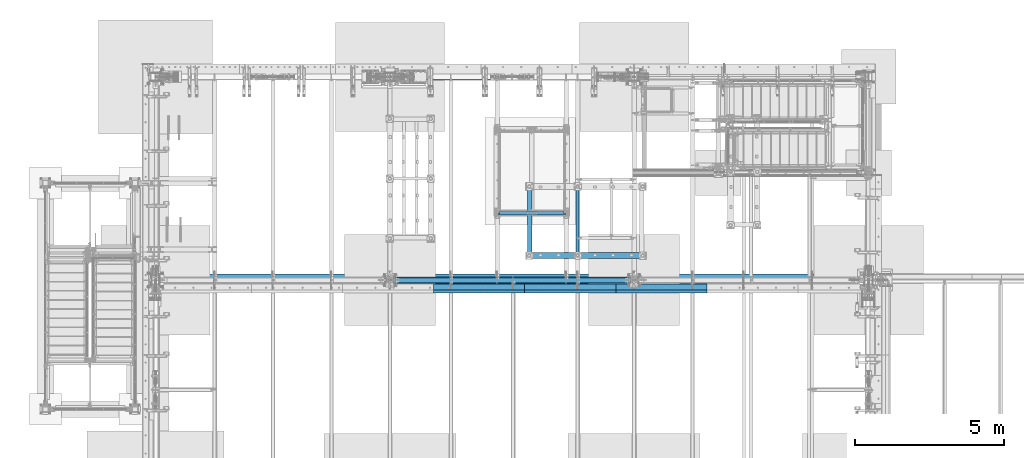
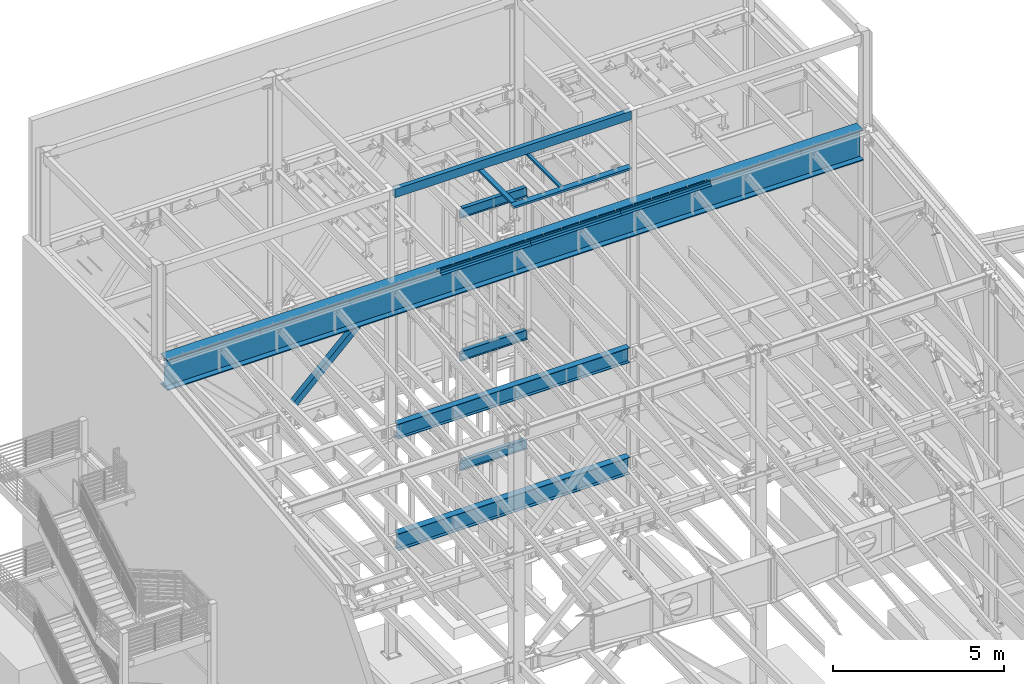
# One storey, part 771 of 1179: 16 beams, 1 member, 12 elements without a shape of their own.
"""IFC2X3 building model written with IfcOpenShell, lengths in millimetres."""

from ifc_helpers import new_model, si_unit, frame, origin_with_axes, place, context, subcontext, project, spatial, faceted_brep, material, type_object, element, aggregate, save


model = new_model("IFC2X3")

# Units and contexts
model_context = context("Model", 3, precision=1e-05, world=origin_with_axes())
body_context = subcontext(model_context, "Body", "Model", "MODEL_VIEW")
ifc_project = project(units=[si_unit("LENGTHUNIT", "METRE", prefix="MILLI"), si_unit("AREAUNIT", "SQUARE_METRE"), si_unit("VOLUMEUNIT", "CUBIC_METRE"), si_unit("MASSUNIT", "GRAM", prefix="KILO"), si_unit("TIMEUNIT", "SECOND"), si_unit("PLANEANGLEUNIT", "RADIAN"), si_unit("SOLIDANGLEUNIT", "STERADIAN"), si_unit("THERMODYNAMICTEMPERATUREUNIT", "DEGREE_CELSIUS"), si_unit("LUMINOUSINTENSITYUNIT", "LUMEN")], contexts=[model_context])

# Site, building, storey
site_placement = place(None, origin_with_axes())
site = spatial("IfcSite", under=ifc_project, at=site_placement, CompositionType="ELEMENT")
building_placement = place(site_placement, origin_with_axes())
building = spatial("IfcBuilding", under=site, at=building_placement, Name="Undefined", CompositionType="ELEMENT")
storey_placement = place(building_placement, origin_with_axes())
storey = spatial("IfcBuildingStorey", under=building, at=storey_placement, Name="Undefined", CompositionType="ELEMENT", Elevation=0.0)

# Assembly, beam
assembly_1_placement = place(storey_placement, origin_with_axes())
assembly_1 = element("IfcElementAssembly", 1, at=assembly_1_placement, inside=storey, Name="BEAM", AssemblyPlace="NOTDEFINED", PredefinedType="RIGID_FRAME")
ifc_material_1 = material(Name="STEEL/A992")
beam_type_1 = type_object("IfcBeamType", Name="W14X22", PredefinedType="NOTDEFINED")
beam_1_placement = place(assembly_1_placement, frame((11874.5, 36639.5, 12944.475), z_axis=(0.0, 0.0, 1.0), x_axis=(1.0, 0.0, 0.0)))
beam_1 = element("IfcBeam", 2, at=beam_1_placement, type_object=beam_type_1, material=ifc_material_1, Name="BEAM", ObjectType="W14X22", context=body_context, shape_type="Brep", body=[
    faceted_brep([(2228.85, -63.5, 174.625), (2228.85, -63.5, 166.6875), (2228.85, -3.17500000000291, 166.6875), (2228.85, -3.17500000000291, 155.574999809263), (2228.85, 3.17495512662572, 155.574999809263), (2228.85, 3.17500000000291, 166.6875), (2228.85, 63.5, 166.6875), (2228.85, 63.5, 174.625), (2229.81672992259, -3.17500000000291, 150.714920291217), (2229.81672992259, 3.17495878513728, 150.714920291217), (2232.56974382307, -3.17500000000291, 146.594743823063), (2232.56974382307, 3.17496188809309, 146.594743823063), (2236.68992029122, -3.17500000000291, 143.841729922586), (2236.68992029122, 3.17496396310162, 143.841729922586), (2241.54999980926, -3.17500000000291, 142.874999999998), (2241.54999980926, 3.17496469425532, 142.874999999998), (2295.525, -3.17500000000291, 142.874999999998), (2295.525, 3.17500000000291, 142.874999999998), (82.5499999999993, -63.5, 174.625), (82.5499999999993, 63.5, 174.625), (82.5499999999993, 63.5, 166.6875), (82.5499999999993, 3.17500000000291, 166.6875), (82.5499999999993, 3.17496616959397, 155.574999809263), (82.5499999999993, -3.17500000000291, 155.574999809263), (82.5499999999993, -3.17500000000291, 166.6875), (82.5499999999993, -63.5, 166.6875), (81.5832700774117, 3.17496981359, 150.714920291217), (81.5832700774117, -3.17500000000291, 150.714920291217), (78.8302561769342, 3.17497290281608, 146.594743823063), (78.8302561769342, -3.17500000000291, 146.594743823063), (74.7100797087805, 3.17497496696888, 143.841729922586), (74.7100797087805, -3.17500000000291, 143.841729922586), (69.8500001907341, 3.17497569180705, 142.874999999998), (69.8500001907341, -3.17500000000291, 142.874999999998), (15.8750000000018, 3.17500000000291, 142.874999999998), (15.8750000000018, -3.17500000000291, 142.874999999998), (15.8750000000018, 3.17500000000291, -166.6875), (15.8750000000018, 3.17549991607666, -174.625), (15.8750000000018, -63.5, -174.625), (15.8750000000018, -63.5, -166.6875), (15.8750000000018, -3.17500000000291, -166.6875), (142.875000000002, 3.17549991607666, -166.6875), (142.875000000002, 3.17549991607666, -174.625), (142.875000000002, 63.5, -166.6875), (142.875000000002, 63.5, -174.625), (2168.52500000002, 3.17502949357731, -166.6875), (2168.52500000016, 63.5, -166.6875), (2168.52500000016, 63.5, -174.625), (2168.52500000016, 3.17561854738597, -174.625), (2295.525, 3.17500000000291, -166.6875), (2295.525, 3.17561854738597, -174.625), (2295.525, -63.5, -174.625), (2295.525, -63.5, -166.6875), (2295.525, -3.17500000000291, -166.6875)], [[[0, 1, 2, 3, 4, 5, 6, 7]], [[8, 9, 4, 3]], [[10, 11, 9, 8]], [[12, 13, 11, 10]], [[14, 15, 13, 12]], [[16, 17, 15, 14]], [[18, 19, 20, 21, 22, 23, 24, 25]], [[23, 22, 26, 27]], [[27, 26, 28, 29]], [[29, 28, 30, 31]], [[31, 30, 32, 33]], [[33, 32, 34, 35]], [[36, 37, 38, 39, 40, 35, 34]], [[41, 42, 37, 36]], [[43, 44, 42, 41]], [[43, 41, 45, 46]], [[44, 43, 46, 47]], [[45, 48, 47, 46]], [[49, 50, 48, 45]], [[51, 38, 37, 42, 44, 47, 48, 50]], [[39, 38, 51, 52]], [[40, 39, 52, 53]], [[12, 10, 8, 3, 2, 24, 23, 27, 29, 31, 33, 35, 40, 53, 16, 14]], [[25, 24, 2, 1]], [[18, 25, 1, 0]], [[19, 18, 0, 7]], [[20, 19, 7, 6]], [[21, 20, 6, 5]], [[49, 45, 41, 36, 34, 32, 30, 28, 26, 22, 21, 5, 4, 9, 11, 13, 15, 17]], [[53, 52, 51, 50, 49, 17, 16]]]),
])
aggregate(assembly_1, [beam_1])

assembly_2_placement = place(storey_placement, origin_with_axes())
assembly_2 = element("IfcElementAssembly", 3, at=assembly_2_placement, inside=storey, Name="BEAM", AssemblyPlace="NOTDEFINED", PredefinedType="RIGID_FRAME")
beam_2_placement = place(assembly_2_placement, frame((11874.5, 36639.5, 7839.075), z_axis=(0.0, 0.0, 1.0), x_axis=(1.0, 0.0, 0.0)))
beam_2 = element("IfcBeam", 4, at=beam_2_placement, type_object=beam_type_1, material=ifc_material_1, Name="BEAM", ObjectType="W14X22", context=body_context, shape_type="Brep", body=[
    faceted_brep([(69.8500001907341, -3.17500000000291, 142.874999999998), (69.8500001907341, 3.17497569180705, 142.874999999998), (15.8750000000018, 3.17500000000291, 142.874999999998), (15.8750000000018, -3.17500000000291, 142.874999999998), (74.7100797087805, -3.17500000000291, 143.841729922586), (74.7100797087805, 3.17497496696888, 143.841729922586), (78.8302561769342, -3.17500000000291, 146.594743823063), (78.8302561769342, 3.17497290281608, 146.594743823063), (81.5832700774117, -3.17500000000291, 150.714920291217), (81.5832700774117, 3.17496981359, 150.714920291217), (82.5499999999993, -3.17500000000291, 155.574999809263), (82.5499999999993, 3.17496616959397, 155.574999809263), (82.5499999999993, -63.5, 174.625), (82.5499999999993, 63.5, 174.625), (82.5499999999993, 63.5, 166.6875), (82.5499999999993, 3.17500000000291, 166.6875), (82.5499999999993, -3.17500000000291, 166.6875), (82.5499999999993, -63.5, 166.6875), (142.875000000002, 63.5, -166.6875), (142.875000000002, 3.17549991607666, -166.6875), (2168.52500000002, 3.17502949357731, -166.6875), (2168.52500000016, 63.5, -166.6875), (15.8750000000018, -3.17500000000291, -166.6875), (15.8750000000018, -63.5, -166.6875), (2295.525, -63.5, -166.6875), (2295.525, -3.17500000000291, -166.6875), (15.8750000000018, -63.5, -174.625), (2295.525, -63.5, -174.625), (2168.52500000016, 63.5, -174.625), (2168.525, 3.17549991607666, -174.625), (2295.525, 3.17549991607666, -174.625), (15.8750000000018, 3.17549991607666, -174.625), (142.875000000002, 3.17549991607666, -174.625), (142.875000000002, 63.5, -174.625), (15.8750000000018, 3.17500000000291, -166.6875), (2295.525, 3.17500000000291, -166.6875), (2295.525, 3.17500000000291, 142.874999999998), (2295.525, -3.17500000000291, 142.874999999998), (2241.54999980926, 3.17496469425532, 142.874999999998), (2241.54999980926, -3.17500000000291, 142.874999999998), (2236.68992029122, 3.17496396310162, 143.841729922586), (2236.68992029122, -3.17500000000291, 143.841729922586), (2232.56974382307, 3.17496188809309, 146.594743823063), (2232.56974382307, -3.17500000000291, 146.594743823063), (2229.81672992259, 3.17495878513728, 150.714920291217), (2229.81672992259, -3.17500000000291, 150.714920291217), (2228.85, 3.17495512662572, 155.574999809263), (2228.85, -3.17500000000291, 155.574999809263), (2228.85, -63.5, 174.625), (2228.85, -63.5, 166.6875), (2228.85, -3.17500000000291, 166.6875), (2228.85, 3.17500000000291, 166.6875), (2228.85, 63.5, 166.6875), (2228.85, 63.5, 174.625)], [[[0, 1, 2, 3]], [[4, 5, 1, 0]], [[6, 7, 5, 4]], [[8, 9, 7, 6]], [[10, 11, 9, 8]], [[12, 13, 14, 15, 11, 10, 16, 17]], [[18, 19, 20, 21]], [[22, 23, 24, 25]], [[23, 26, 27, 24]], [[28, 29, 30, 27, 26, 31, 32, 33]], [[19, 32, 31, 34]], [[18, 33, 32, 19]], [[33, 18, 21, 28]], [[20, 29, 28, 21]], [[35, 30, 29, 20]], [[25, 24, 27, 30, 35, 36, 37]], [[37, 36, 38, 39]], [[39, 38, 40, 41]], [[41, 40, 42, 43]], [[43, 42, 44, 45]], [[45, 44, 46, 47]], [[48, 49, 50, 47, 46, 51, 52, 53]], [[12, 17, 49, 48]], [[17, 16, 50, 49]], [[41, 43, 45, 47, 50, 16, 10, 8, 6, 4, 0, 3, 22, 25, 37, 39]], [[34, 31, 26, 23, 22, 3, 2]], [[35, 20, 19, 34, 2, 1, 5, 7, 9, 11, 15, 51, 46, 44, 42, 40, 38, 36]], [[15, 14, 52, 51]], [[14, 13, 53, 52]], [[13, 12, 48, 53]]]),
])
aggregate(assembly_2, [beam_2])

assembly_3_placement = place(storey_placement, origin_with_axes())
assembly_3 = element("IfcElementAssembly", 5, at=assembly_3_placement, inside=storey, Name="BEAM", AssemblyPlace="NOTDEFINED", PredefinedType="RIGID_FRAME")
beam_3_placement = place(assembly_3_placement, frame((11874.5, 36639.5, 3927.475), z_axis=(0.0, 0.0, 1.0), x_axis=(1.0, 0.0, 0.0)))
beam_3 = element("IfcBeam", 6, at=beam_3_placement, type_object=beam_type_1, material=ifc_material_1, Name="BEAM", ObjectType="W14X22", context=body_context, shape_type="Brep", body=[
    faceted_brep([(69.8501110149282, -3.17500000000291, 142.875), (69.8501110149282, 3.17497732211632, 142.875), (15.8751123323145, 3.17500000000291, 142.875), (15.875112491065, -3.17500000000291, 142.875), (74.7101905329746, -3.17500000000291, 143.841729922588), (74.7101905329746, 3.174976675793, 143.841729922588), (78.8303670011283, -3.17500000000291, 146.594743823066), (78.8303670011283, 3.17497483522311, 146.594743823066), (81.5833809016058, -3.17500000000291, 150.71492029122), (81.5833809016058, 3.17497208061104, 150.71492029122), (82.5501108241933, -3.17500000000291, 155.574999809265), (82.5501108241933, 3.17496883132844, 155.574999809265), (82.5501108241933, -63.5, 174.625), (82.5501108241933, 63.5, 174.625), (82.5501108241933, 63.5, 166.6875), (82.5501108241933, 3.17500000000291, 166.6875), (82.5501108241933, -3.17500000000291, 166.6875), (82.5501108241933, -63.5, 166.6875), (2168.5251123317, 3.17500000000291, -166.6875), (2168.52511082358, 63.5, -166.6875), (142.875110823743, 63.5, -166.6875), (142.875112331867, 3.17547110273154, -166.6875), (15.875112491065, -3.17500000000291, -166.6875), (15.8751139991891, -63.5, -166.6875), (2295.52511399919, -63.5, -166.6875), (2295.52511249106, -3.17500000000291, -166.6875), (15.8751139991891, -63.5, -174.625), (2295.52511399919, -63.5, -174.625), (2168.52511082358, 63.5, -174.625), (2168.5251123317, 3.17552491938841, -174.625), (2295.5251123323, 3.17552809441258, -174.625), (15.8751123323036, 3.17546792770736, -174.625), (142.875112331867, 3.17547110273154, -174.625), (142.875110823743, 63.5, -174.625), (15.8751123323145, 3.17500000000291, -166.6875), (2295.52511233231, 3.17500000000291, -166.6875), (2295.52511233231, 3.17500000000291, 142.875), (2295.52511249106, -3.17500000000291, 142.875), (2241.55011380846, 3.17500000000291, 142.875), (2241.55011380846, -3.17500000000291, 142.875), (2236.69003429041, 3.17500000000291, 143.841729922588), (2236.69003429041, -3.17500000000291, 143.841729922588), (2232.56985782226, 3.17500000000291, 146.594743823066), (2232.56985782226, -3.17500000000291, 146.594743823066), (2229.81684392178, 3.17500000000291, 150.71492029122), (2229.81684392178, -3.17500000000291, 150.71492029122), (2228.85011399919, 3.17500000000291, 155.574999809265), (2228.85011399919, -3.17500000000291, 155.574999809265), (2228.85011399919, -63.5, 174.625), (2228.85011399919, -63.5, 166.6875), (2228.85011399919, -3.17500000000291, 166.6875), (2228.85011399919, 3.17500000000291, 166.6875), (2228.85011399919, 63.5, 166.6875), (2228.85011399919, 63.5, 174.625)], [[[0, 1, 2, 3]], [[4, 5, 1, 0]], [[6, 7, 5, 4]], [[8, 9, 7, 6]], [[10, 11, 9, 8]], [[12, 13, 14, 15, 11, 10, 16, 17]], [[18, 19, 20, 21]], [[22, 23, 24, 25]], [[23, 26, 27, 24]], [[28, 29, 30, 27, 26, 31, 32, 33]], [[21, 32, 31, 34]], [[20, 33, 32, 21]], [[19, 28, 33, 20]], [[18, 29, 28, 19]], [[35, 30, 29, 18]], [[25, 24, 27, 30, 35, 36, 37]], [[37, 36, 38, 39]], [[39, 38, 40, 41]], [[41, 40, 42, 43]], [[43, 42, 44, 45]], [[45, 44, 46, 47]], [[48, 49, 50, 47, 46, 51, 52, 53]], [[49, 48, 12, 17]], [[50, 49, 17, 16]], [[8, 6, 4, 0, 3, 22, 25, 37, 39, 41, 43, 45, 47, 50, 16, 10]], [[34, 31, 26, 23, 22, 3, 2]], [[51, 46, 44, 42, 40, 38, 36, 35, 18, 21, 34, 2, 1, 5, 7, 9, 11, 15]], [[52, 51, 15, 14]], [[53, 52, 14, 13]], [[48, 53, 13, 12]]]),
])
aggregate(assembly_3, [beam_3])

assembly_4_placement = place(storey_placement, origin_with_axes())
assembly_4 = element("IfcElementAssembly", 7, at=assembly_4_placement, inside=storey, Name="BENT_PLATE", AssemblyPlace="NOTDEFINED", PredefinedType="RIGID_FRAME")
ifc_material_2 = material(Name="STEEL/A36")
beam_type_2 = type_object("IfcBeamType", PredefinedType="NOTDEFINED")
beam_4_placement = place(assembly_4_placement, frame((17365.6625008538, 34061.4000000402, 13197.7319337816), z_axis=(1.0, 0.0, 0.0), x_axis=(0.0, 0.0, -1.0)))
beam_4 = element("IfcBeam", 8, at=beam_4_placement, type_object=beam_type_2, material=ifc_material_2, Name="BENT_PLATE", context=body_context, shape_type="Brep", body=[
    faceted_brep([(0.0, -3.17499999999927, -1524.0), (6.00266503170133e-10, -3.17499999922438, 1524.00000000052), (6.00266503170133e-10, 3.17500000077416, 1524.00000000052), (0.0, 3.17499999999927, -1524.0), (101.599999999993, 3.17500000000291, 1524.0), (101.599999999993, 3.17500000000291, -1524.0), (95.9271295501057, -3.17500000000291, -1524.0), (95.9271295501057, -3.17500000000291, 1524.0), (113.008063243053, -97.7824964679457, 1524.0), (113.008063243053, -97.7824964679457, -1524.0), (106.698219713815, -98.4955004206422, 1524.0), (106.698219713815, -98.4955004206422, -1524.0)], [[[0, 1, 2, 3]], [[3, 2, 4, 5]], [[1, 0, 6, 7]], [[5, 4, 8, 9]], [[4, 2, 1, 7, 10, 8]], [[7, 6, 11, 10]], [[6, 0, 3, 5, 9, 11]], [[10, 11, 9, 8]]]),
])
aggregate(assembly_4, [beam_4])

assembly_5_placement = place(storey_placement, origin_with_axes())
assembly_5 = element("IfcElementAssembly", 9, at=assembly_5_placement, inside=storey, Name="BENT_PLATE", AssemblyPlace="NOTDEFINED", PredefinedType="RIGID_FRAME")
beam_5_placement = place(assembly_5_placement, frame((14317.662500843, 34061.4000000402, 13197.7319337816), z_axis=(1.0, 0.0, 0.0), x_axis=(0.0, 0.0, -1.0)))
beam_5 = element("IfcBeam", 10, at=beam_5_placement, type_object=beam_type_2, material=ifc_material_2, Name="BENT_PLATE", context=body_context, shape_type="Brep", body=[
    faceted_brep([(0.0, -3.17499999999927, -1524.0), (6.00266503170133e-10, -3.17499999922438, 1524.00000000052), (6.00266503170133e-10, 3.17500000077416, 1524.00000000052), (0.0, 3.17499999999927, -1524.0), (101.599999999993, 3.17500000000291, 1524.0), (101.599999999993, 3.17500000000291, -1524.0), (95.9271295501057, -3.17500000000291, -1524.0), (95.9271295501057, -3.17500000000291, 1524.0), (113.008063243053, -97.7824964679457, 1524.0), (113.008063243053, -97.7824964679457, -1524.0), (106.698219713815, -98.4955004206422, 1524.0), (106.698219713815, -98.4955004206422, -1524.0)], [[[0, 1, 2, 3]], [[3, 2, 4, 5]], [[1, 0, 6, 7]], [[5, 4, 8, 9]], [[4, 2, 1, 7, 10, 8]], [[7, 6, 11, 10]], [[6, 0, 3, 5, 9, 11]], [[10, 11, 9, 8]]]),
])
aggregate(assembly_5, [beam_5])

assembly_6_placement = place(storey_placement, origin_with_axes())
assembly_6 = element("IfcElementAssembly", 11, at=assembly_6_placement, inside=storey, Name="BENT_PLATE", AssemblyPlace="NOTDEFINED", PredefinedType="RIGID_FRAME")
beam_6_placement = place(assembly_6_placement, frame((11269.6625008321, 34061.4000000402, 13197.7319337816), z_axis=(1.0, 0.0, 0.0), x_axis=(0.0, 0.0, -1.0)))
beam_6 = element("IfcBeam", 12, at=beam_6_placement, type_object=beam_type_2, material=ifc_material_2, Name="BENT_PLATE", context=body_context, shape_type="Brep", body=[
    faceted_brep([(0.0, -3.17499999999927, -1524.0), (6.00266503170133e-10, -3.17499999922438, 1524.00000000052), (6.00266503170133e-10, 3.17500000077416, 1524.00000000052), (0.0, 3.17499999999927, -1524.0), (101.599999999993, 3.17500000000291, 1524.0), (101.599999999993, 3.17500000000291, -1524.0), (95.9271295501057, -3.17500000000291, -1524.0), (95.9271295501057, -3.17500000000291, 1524.0), (113.008063243053, -97.7824964679457, 1524.0), (113.008063243053, -97.7824964679457, -1524.0), (106.698219713815, -98.4955004206422, 1524.0), (106.698219713815, -98.4955004206422, -1524.0)], [[[0, 1, 2, 3]], [[3, 2, 4, 5]], [[1, 0, 6, 7]], [[5, 4, 8, 9]], [[4, 2, 1, 7, 10, 8]], [[7, 6, 11, 10]], [[6, 0, 3, 5, 9, 11]], [[10, 11, 9, 8]]]),
])
aggregate(assembly_6, [beam_6])

# Assembly, member
assembly_7_placement = place(storey_placement, origin_with_axes())
assembly_7 = element("IfcElementAssembly", 13, at=assembly_7_placement, inside=storey, Name="None", AssemblyPlace="NOTDEFINED", PredefinedType="RIGID_FRAME")
member_type = type_object("IfcMemberType", Name="HSS8X8X3/16", PredefinedType="NOTDEFINED")
member_placement = place(assembly_7_placement, frame((8920.66532777489, 41198.8, 4439.89020399566), z_axis=(0.0, -1.0, 0.0), x_axis=(0.722641857060828, 0.0, 0.691222646058184)))
member = element("IfcMember", 14, at=member_placement, type_object=member_type, material=ifc_material_1, Name="None", ObjectType="HSS8X8X3/16", context=body_context, shape_type="Brep", body=[
    faceted_brep([(-3.63797880709171e-12, 96.8374999999978, -96.8375000000015), (-3.63797880709171e-12, -96.8374999999978, -96.8375000000015), (3864.89737425295, -96.8375000001724, -96.8375000000015), (3864.89737425283, 96.8374999999396, -96.8375000000015), (-3.63797880709171e-12, -96.8374999999978, 96.8375000000015), (3864.89737425295, -96.8375000001724, 96.8375000000015), (-3.63797880709171e-12, 96.8374999999978, 96.8375000000015), (3864.89737425283, 96.8374999999396, 96.8375000000015), (-3.63797880709171e-12, 101.599999999999, -101.599999999999), (-3.63797880709171e-12, 101.599999999999, 101.599999999999), (3864.89737425282, 101.599999999942, 101.599999999999), (3864.89737425282, 101.599999999942, -101.599999999999), (0.0, -101.599999999999, 101.599999999999), (3864.89737425295, -101.600000000173, 101.599999999999), (0.0, -101.599999999999, -101.599999999999), (3864.89737425295, -101.600000000173, -101.599999999999)], [[[0, 1, 2, 3]], [[1, 4, 5, 2]], [[4, 6, 7, 5]], [[6, 0, 3, 7]], [[8, 9, 10, 11]], [[9, 12, 13, 10]], [[12, 14, 15, 13]], [[14, 8, 11, 15]], [[13, 15, 11, 10], [5, 7, 3, 2]], [[14, 12, 9, 8], [6, 4, 1, 0]]]),
])
aggregate(assembly_7, [member])

# Assembly, beams
assembly_8_placement = place(storey_placement, origin_with_axes())
assembly_8 = element("IfcElementAssembly", 15, at=assembly_8_placement, inside=storey, Name="BEAM", AssemblyPlace="NOTDEFINED", PredefinedType="RIGID_FRAME")
beam_type_3 = type_object("IfcBeamType", PredefinedType="NOTDEFINED")
beam_7_placement = place(assembly_8_placement, frame((17365.6625008164, 34267.775, 13122.275), z_axis=(1.0, 0.0, 0.0), x_axis=(0.0, -1.0, 0.0)))
beam_7 = element("IfcBeam", 16, at=beam_7_placement, type_object=beam_type_3, material=ifc_material_2, Name="BENT_PLATE", context=body_context, shape_type="Brep", body=[
    faceted_brep([(0.0, -3.17499999999927, -1524.0), (6.00266503170133e-10, -3.17499999922438, 1524.00000000052), (6.00266503170133e-10, 3.17500000077416, 1524.00000000052), (0.0, 3.17499999999927, -1524.0), (203.199999999997, 3.17499999999927, 1524.0), (203.199999999997, 3.17499999999927, -1524.0), (196.849999999991, -3.17499999999927, -1524.0), (196.849999999991, -3.17499999999927, 1524.0), (203.199999999997, -130.175000000001, 1524.0), (203.199999999997, -130.175000000001, -1524.0), (196.849999999991, -130.175000000001, 1524.0), (196.849999999991, -130.175000000001, -1524.0)], [[[0, 1, 2, 3]], [[3, 2, 4, 5]], [[1, 0, 6, 7]], [[5, 4, 8, 9]], [[4, 2, 1, 7, 10, 8]], [[7, 6, 11, 10]], [[6, 0, 3, 5, 9, 11]], [[10, 11, 9, 8]]]),
])
beam_8_placement = place(assembly_8_placement, frame((14317.6625008164, 34267.775, 13122.275), z_axis=(1.0, 0.0, 0.0), x_axis=(0.0, -1.0, 0.0)))
beam_8 = element("IfcBeam", 17, at=beam_8_placement, type_object=beam_type_3, material=ifc_material_2, Name="BENT_PLATE", context=body_context, shape_type="Brep", body=[
    faceted_brep([(0.0, -3.17499999999927, -1524.0), (6.00266503170133e-10, -3.17499999922438, 1524.00000000052), (6.00266503170133e-10, 3.17500000077416, 1524.00000000052), (0.0, 3.17499999999927, -1524.0), (203.199999999997, 3.17499999999927, 1524.0), (203.199999999997, 3.17499999999927, -1524.0), (196.849999999991, -3.17499999999927, -1524.0), (196.849999999991, -3.17499999999927, 1524.0), (203.199999999997, -130.175000000001, 1524.0), (203.199999999997, -130.175000000001, -1524.0), (196.849999999991, -130.175000000001, 1524.0), (196.849999999991, -130.175000000001, -1524.0)], [[[0, 1, 2, 3]], [[3, 2, 4, 5]], [[1, 0, 6, 7]], [[5, 4, 8, 9]], [[4, 2, 1, 7, 10, 8]], [[7, 6, 11, 10]], [[6, 0, 3, 5, 9, 11]], [[10, 11, 9, 8]]]),
])
beam_9_placement = place(assembly_8_placement, frame((11269.6625008164, 34267.775, 13122.275), z_axis=(1.0, 0.0, 0.0), x_axis=(0.0, -1.0, 0.0)))
beam_9 = element("IfcBeam", 18, at=beam_9_placement, type_object=beam_type_3, material=ifc_material_2, Name="BENT_PLATE", context=body_context, shape_type="Brep", body=[
    faceted_brep([(0.0, -3.17499999999927, -1524.0), (6.00266503170133e-10, -3.17499999922438, 1524.00000000052), (6.00266503170133e-10, 3.17500000077416, 1524.00000000052), (0.0, 3.17499999999927, -1524.0), (203.199999999997, 3.17499999999927, 1524.0), (203.199999999997, 3.17499999999927, -1524.0), (196.849999999991, -3.17499999999927, -1524.0), (196.849999999991, -3.17499999999927, 1524.0), (203.199999999997, -130.175000000001, 1524.0), (203.199999999997, -130.175000000001, -1524.0), (196.849999999991, -130.175000000001, 1524.0), (196.849999999991, -130.175000000001, -1524.0)], [[[0, 1, 2, 3]], [[3, 2, 4, 5]], [[1, 0, 6, 7]], [[5, 4, 8, 9]], [[4, 2, 1, 7, 10, 8]], [[7, 6, 11, 10]], [[6, 0, 3, 5, 9, 11]], [[10, 11, 9, 8]]]),
])

assembly_9_placement = place(storey_placement, origin_with_axes())
assembly_9 = element("IfcElementAssembly", 19, at=assembly_9_placement, inside=storey, Name="FRAME", AssemblyPlace="NOTDEFINED", PredefinedType="RIGID_FRAME")
ifc_material_3 = material()
beam_type_4 = type_object("IfcBeamType", Name="HSS4X3X1/4", PredefinedType="NOTDEFINED")
beam_10_placement = place(assembly_9_placement, frame((14566.9, 35318.7, 13722.35), z_axis=(1.0, 0.0, 0.0), x_axis=(0.0, 1.0, 0.0)))
beam_10 = element("IfcBeam", 20, at=beam_10_placement, type_object=beam_type_4, material=ifc_material_3, Name="BEAM", ObjectType="HSS4X3X1/4", context=body_context, shape_type="Brep", body=[
    faceted_brep([(0.0, 31.75, -44.4499999999971), (0.0, -31.75, -44.4499999999971), (2108.2, -31.75, -44.4500000000007), (2108.2, 31.75, -44.4500000000007), (0.0, -31.75, 44.4499999999971), (2108.2, -31.75, 44.4500000000007), (0.0, 31.75, 44.4499999999971), (2108.2, 31.75, 44.4500000000007), (0.0, 38.0999999999985, -50.8000000000002), (1.45519152283669e-11, 38.1000000000004, 50.8000000000002), (2108.2, 38.1000000000004, 50.7999999999993), (2108.2, 38.1000000000004, -50.7999999999993), (0.0, -38.0999999999985, 50.8000000000002), (2108.2, -38.1000000000004, 50.7999999999993), (0.0, -38.0999999999985, -50.8000000000002), (2108.2, -38.1000000000004, -50.7999999999993)], [[[0, 1, 2, 3]], [[1, 4, 5, 2]], [[4, 6, 7, 5]], [[6, 0, 3, 7]], [[8, 9, 10, 11]], [[9, 12, 13, 10]], [[12, 14, 15, 13]], [[14, 8, 11, 15]], [[13, 15, 11, 10], [5, 7, 3, 2]], [[14, 12, 9, 8], [6, 4, 1, 0]]]),
])
beam_type_5 = type_object("IfcBeamType", Name="HSS6X3X1/4", PredefinedType="NOTDEFINED")
beam_11_placement = place(assembly_9_placement, frame((12966.7, 35318.7, 13722.35), z_axis=(1.0, 0.0, 0.0), x_axis=(0.0, 1.0, 0.0)))
beam_11 = element("IfcBeam", 21, at=beam_11_placement, type_object=beam_type_5, material=ifc_material_3, Name="BEAM", ObjectType="HSS6X3X1/4", context=body_context, shape_type="Brep", body=[
    faceted_brep([(0.0, 31.75, -69.8499999999985), (0.0, -31.75, -69.8499999999985), (2108.2, -31.75, -69.8499999999985), (2108.2, 31.75, -69.8499999999985), (0.0, -31.75, 69.8499999999985), (2108.2, -31.75, 69.8499999999985), (0.0, 31.75, 69.8499999999985), (2108.2, 31.75, 69.8499999999985), (0.0, 38.0999999999985, -76.1999999999998), (0.0, 38.0999999999985, 76.1999999999998), (2108.2, 38.1000000000004, 76.2000000000007), (2108.2, 38.1000000000004, -76.2000000000007), (0.0, -38.0999999999985, 76.1999999999998), (2108.2, -38.1000000000004, 76.2000000000007), (0.0, -38.0999999999985, -76.1999999999998), (2108.2, -38.1000000000004, -76.2000000000007)], [[[0, 1, 2, 3]], [[1, 4, 5, 2]], [[4, 6, 7, 5]], [[6, 0, 3, 7]], [[8, 9, 10, 11]], [[9, 12, 13, 10]], [[12, 14, 15, 13]], [[14, 8, 11, 15]], [[13, 15, 11, 10], [5, 7, 3, 2]], [[14, 12, 9, 8], [6, 4, 1, 0]]]),
])
beam_type_6 = type_object("IfcBeamType", Name="HSS8X3X1/4", PredefinedType="NOTDEFINED")
beam_12_placement = place(assembly_9_placement, frame((12839.7, 35217.1, 13722.35), z_axis=(0.0, -1.0, 0.0), x_axis=(1.0, 0.0, 0.0)))
beam_12 = element("IfcBeam", 22, at=beam_12_placement, type_object=beam_type_6, material=ifc_material_3, Name="BEAM", ObjectType="HSS8X3X1/4", context=body_context, shape_type="Brep", body=[
    faceted_brep([(4.76249999999709, 31.75, -95.25), (4.76249999999709, -31.75, -95.25), (3995.7375, -31.75, -95.25), (3995.7375, 31.75, -95.25), (4.76249999999709, -31.75, 95.25), (3995.7375, -31.75, 95.25), (4.76249999999709, 31.75, 95.25), (3995.7375, 31.75, 95.25), (4.76249999999709, 38.1000000000004, -101.599999999999), (4.76249999999709, 38.1000000000004, 101.599999999999), (3995.7375, 38.1000000000004, 101.599999999999), (3995.7375, 38.1000000000004, -101.599999999999), (4.76249999999709, -38.1000000000004, 101.599999999999), (3995.7375, -38.1000000000004, 101.599999999999), (4.76249999999709, -38.1000000000004, -101.599999999999), (3995.7375, -38.1000000000004, -101.599999999999)], [[[0, 1, 2, 3]], [[1, 4, 5, 2]], [[4, 6, 7, 5]], [[6, 0, 3, 7]], [[8, 9, 10, 11]], [[9, 12, 13, 10]], [[12, 14, 15, 13]], [[14, 8, 11, 15]], [[13, 15, 11, 10], [5, 7, 3, 2]], [[14, 12, 9, 8], [6, 4, 1, 0]]]),
])
aggregate(assembly_9, [beam_10, beam_11, beam_12])

# Assembly, beam
assembly_10_placement = place(storey_placement, origin_with_axes())
assembly_10 = element("IfcElementAssembly", 23, at=assembly_10_placement, inside=storey, Name="BEAM", AssemblyPlace="NOTDEFINED", PredefinedType="RIGID_FRAME")
beam_type_7 = type_object("IfcBeamType", Name="HSS12X6X3/8", PredefinedType="NOTDEFINED")
beam_13_placement = place(assembly_10_placement, frame((8369.3, 34391.6, 16275.05), z_axis=(0.0, 0.0, 1.0), x_axis=(1.0, 0.0, 0.0)))
beam_13 = element("IfcBeam", 24, at=beam_13_placement, type_object=beam_type_7, material=ifc_material_3, Name="BEAM", ObjectType="HSS12X6X3/8", context=body_context, shape_type="Brep", body=[
    faceted_brep([(4.76249999999709, 66.6749999999993, -142.875), (4.76249999999709, -66.6749999999993, -142.875), (7996.2375, -66.6750000000029, -142.875), (7996.2375, 66.6750000000029, -142.875), (4.76249999999709, -66.6749999999993, 142.875000000002), (7996.2375, -66.6750000000029, 142.875000000002), (4.76249999999709, 66.6749999999993, 142.875000000002), (7996.2375, 66.6750000000029, 142.875000000002), (4.76249999999709, 76.2000000000007, -152.4), (4.76249999999709, 76.2000000000007, 152.4), (7996.2375, 76.1999999999971, 152.4), (7996.2375, 76.1999999999971, -152.4), (4.76249999999709, -76.2000000000007, 152.4), (7996.2375, -76.1999999999971, 152.4), (4.76249999999709, -76.2000000000007, -152.4), (7996.2375, -76.1999999999971, -152.4)], [[[0, 1, 2, 3]], [[1, 4, 5, 2]], [[4, 6, 7, 5]], [[6, 0, 3, 7]], [[8, 9, 10, 11]], [[9, 12, 13, 10]], [[12, 14, 15, 13]], [[14, 8, 11, 15]], [[13, 15, 11, 10], [5, 7, 3, 2]], [[14, 12, 9, 8], [6, 4, 1, 0]]]),
])
aggregate(assembly_10, [beam_13])

# Beam
beam_type_8 = type_object("IfcBeamType", Name="W44X262", PredefinedType="NOTDEFINED")
beam_14_placement = place(assembly_8_placement, frame((431.8, 34391.6, 12569.825), z_axis=(0.0, 0.0, 1.0), x_axis=(1.0, 0.0, 0.0)))
beam_14 = element("IfcBeam", 25, at=beam_14_placement, type_object=beam_type_8, material=ifc_material_1, Name="BEAM", ObjectType="W44X262", context=body_context, shape_type="Brep", body=[
    faceted_brep([(169.862500816437, -200.025000000001, -549.275), (169.862500816437, 200.025000000001, -549.275), (23701.375, 200.025000000001, -549.275), (23701.375, -200.025000000001, -549.275), (169.862500816437, -200.025000000001, -512.762500000001), (169.862500816437, -10.3187499999985, -512.762500000001), (169.862500816437, -10.3187499999985, 512.762500000001), (169.862500816437, -200.025000000001, 512.762500000001), (169.862500816437, -200.025000000001, 549.275), (169.862500816437, 200.025000000001, 549.275), (169.862500816437, 200.025000000001, 512.762500000001), (169.862500816437, 10.3187499999985, 512.762500000001), (169.862500816437, 10.3187499999985, -512.762500000001), (169.862500816437, 200.025000000001, -512.762500000001), (23701.375, -200.025000000001, -512.762500000001), (23701.375, -10.3187499999985, -512.762500000001), (23701.375, -10.3187499999985, 512.762500000001), (23701.375, -200.025000000001, 512.762500000001), (23701.375, -200.025000000001, 549.275), (23701.375, 200.025000000001, 549.275), (23701.375, 200.025000000001, 512.762500000001), (23701.375, 10.3187499999985, 512.762500000001), (23701.375, 10.3187499999985, -512.762500000001), (23701.375, 200.025000000001, -512.762500000001)], [[[0, 1, 2, 3]], [[0, 4, 5, 6, 7, 8, 9, 10, 11, 12, 13, 1]], [[5, 4, 14, 15]], [[6, 5, 15, 16]], [[7, 6, 16, 17]], [[8, 7, 17, 18]], [[9, 8, 18, 19]], [[10, 9, 19, 20]], [[11, 10, 20, 21]], [[12, 11, 21, 22]], [[13, 12, 22, 23]], [[1, 13, 23, 2]], [[22, 21, 20, 19, 18, 17, 16, 15, 14, 3, 2, 23]], [[4, 0, 3, 14]]]),
])

aggregate(assembly_8, [beam_7, beam_8, beam_9, beam_14])

# Assembly, beam
assembly_11_placement = place(storey_placement, origin_with_axes())
assembly_11 = element("IfcElementAssembly", 26, at=assembly_11_placement, inside=storey, Name="BEAM", AssemblyPlace="NOTDEFINED", PredefinedType="RIGID_FRAME")
beam_type_9 = type_object("IfcBeamType", Name="W21X62", PredefinedType="NOTDEFINED")
beam_15_placement = place(assembly_11_placement, frame((8280.4, 34391.6, 7747.0), z_axis=(0.0, 0.0, 1.0), x_axis=(1.0, 0.0, 0.0)))
beam_15 = element("IfcBeam", 27, at=beam_15_placement, type_object=beam_type_9, material=ifc_material_1, Name="BEAM", ObjectType="W21X62", context=body_context, shape_type="Brep", body=[
    faceted_brep([(168.275000000001, -104.775000000001, -266.7), (168.275000000001, 104.775000000001, -266.7), (8010.525, 104.775000000001, -266.7), (8010.525, -104.775000000001, -266.7), (168.275000000001, -104.775000000001, -250.825), (168.275000000001, -4.76249999999709, -250.825), (168.275000000001, -4.76249999999709, 250.825), (168.275000000001, -104.775000000001, 250.825), (168.275000000001, -104.775000000001, 266.7), (168.275000000001, 104.775000000001, 266.7), (168.275000000001, 104.775000000001, 250.825), (168.275000000001, 4.76249999999709, 250.825), (168.275000000001, 4.76249999999709, -250.825), (168.275000000001, 104.775000000001, -250.825), (8010.525, -104.775000000001, -250.825), (8010.525, -4.76249999999709, -250.825), (8010.525, -4.76249999999709, 250.825), (8010.525, -104.775000000001, 250.825), (8010.525, -104.775000000001, 266.7), (8010.525, 104.775000000001, 266.7), (8010.525, 104.775000000001, 250.825), (8010.525, 4.76249999999709, 250.825), (8010.525, 4.76249999999709, -250.825), (8010.525, 104.775000000001, -250.825)], [[[0, 1, 2, 3]], [[0, 4, 5, 6, 7, 8, 9, 10, 11, 12, 13, 1]], [[5, 4, 14, 15]], [[6, 5, 15, 16]], [[7, 6, 16, 17]], [[8, 7, 17, 18]], [[9, 8, 18, 19]], [[10, 9, 19, 20]], [[11, 10, 20, 21]], [[12, 11, 21, 22]], [[13, 12, 22, 23]], [[1, 13, 23, 2]], [[22, 21, 20, 19, 18, 17, 16, 15, 14, 3, 2, 23]], [[4, 0, 3, 14]]]),
])
aggregate(assembly_11, [beam_15])

assembly_12_placement = place(storey_placement, origin_with_axes())
assembly_12 = element("IfcElementAssembly", 28, at=assembly_12_placement, inside=storey, Name="BEAM", AssemblyPlace="NOTDEFINED", PredefinedType="RIGID_FRAME")
beam_type_10 = type_object("IfcBeamType", Name="W24X68", PredefinedType="NOTDEFINED")
beam_16_placement = place(assembly_12_placement, frame((8280.4, 34391.6, 3800.475), z_axis=(0.0, 0.0, 1.0), x_axis=(1.0, 0.0, 0.0)))
beam_16 = element("IfcBeam", 29, at=beam_16_placement, type_object=beam_type_10, material=ifc_material_1, Name="BEAM", ObjectType="W24X68", context=body_context, shape_type="Brep", body=[
    faceted_brep([(168.275000000001, -114.300000000003, -301.625), (168.275000000001, 114.300000000003, -301.625), (8010.525, 114.300000000003, -301.625), (8010.525, -114.300000000003, -301.625), (168.275000000001, -114.300000000003, -287.3375), (168.275000000001, -5.55625000000146, -287.3375), (168.275000000001, -5.55625000000146, 287.3375), (168.275000000001, -114.300000000003, 287.3375), (168.275000000001, -114.300000000003, 301.625), (168.275000000001, 114.300000000003, 301.625), (168.275000000001, 114.300000000003, 287.3375), (168.275000000001, 5.55625000000146, 287.3375), (168.275000000001, 5.55625000000146, -287.3375), (168.275000000001, 114.300000000003, -287.3375), (8010.525, -114.300000000003, -287.3375), (8010.525, -5.55625000000146, -287.3375), (8010.525, -5.55625000000146, 287.3375), (8010.525, -114.300000000003, 287.3375), (8010.525, -114.300000000003, 301.625), (8010.525, 114.300000000003, 301.625), (8010.525, 114.300000000003, 287.3375), (8010.525, 5.55625000000146, 287.3375), (8010.525, 5.55625000000146, -287.3375), (8010.525, 114.300000000003, -287.3375)], [[[0, 1, 2, 3]], [[0, 4, 5, 6, 7, 8, 9, 10, 11, 12, 13, 1]], [[5, 4, 14, 15]], [[6, 5, 15, 16]], [[7, 6, 16, 17]], [[8, 7, 17, 18]], [[9, 8, 18, 19]], [[10, 9, 19, 20]], [[11, 10, 20, 21]], [[12, 11, 21, 22]], [[13, 12, 22, 23]], [[1, 13, 23, 2]], [[22, 21, 20, 19, 18, 17, 16, 15, 14, 3, 2, 23]], [[4, 0, 3, 14]]]),
])
aggregate(assembly_12, [beam_16])

save(model, "model.ifc")
